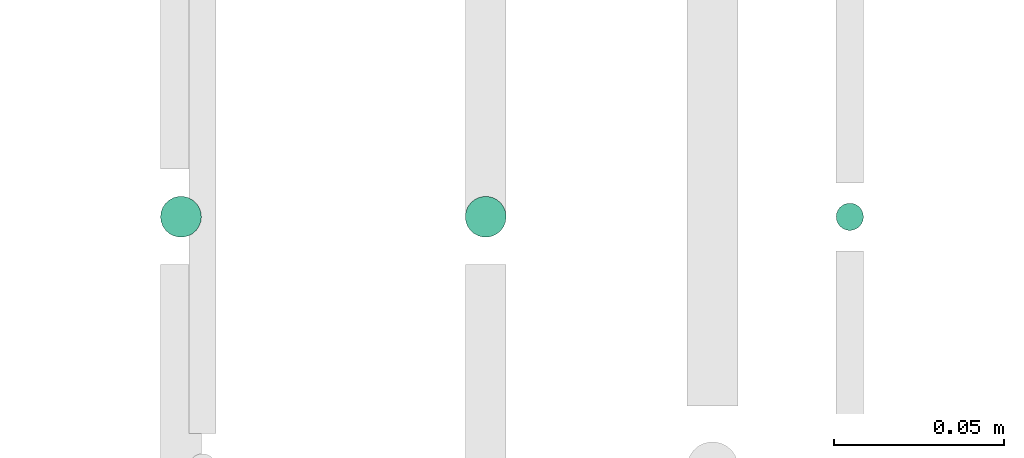
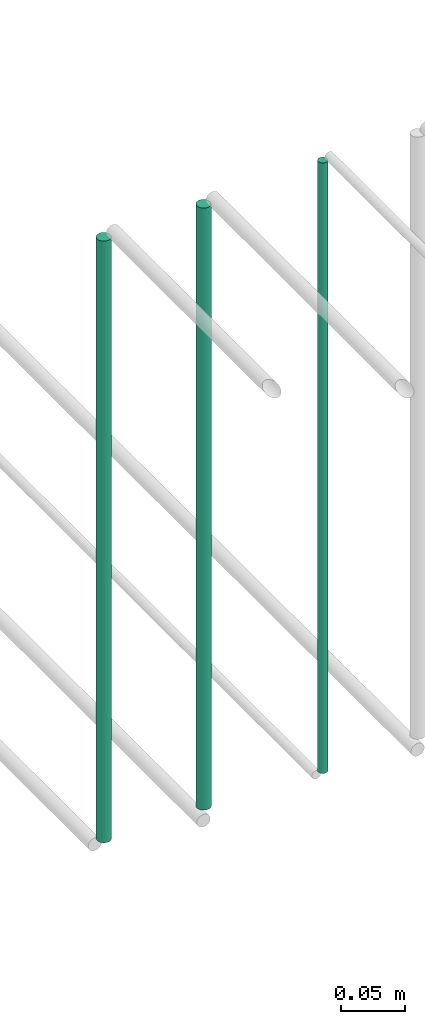
# One storey, part 214 of 331: 3 flow segments.
"""IFC2X3 building model written with IfcOpenShell, lengths in millimetres."""

from ifc_helpers import new_model, entity, si_unit, converted_unit, derived_unit, direction, frame, origin, origin_2d_with_axis, place, context, subcontext, project, spatial, circle, extrude, type_object, element, save


model = new_model("IFC2X3")

# Units and contexts
model_context = context("Model", 3, precision=0.01, world=origin(), true_north=direction((6.12303176911189e-17, 1.0)))
body_context = subcontext(model_context, "Body", "Model", "MODEL_VIEW")
ifc_project = project(units=[si_unit("LENGTHUNIT", "METRE", prefix="MILLI"), si_unit("AREAUNIT", "SQUARE_METRE"), si_unit("VOLUMEUNIT", "CUBIC_METRE"), converted_unit("PLANEANGLEUNIT", "DEGREE", entity("IfcRatioMeasure", 0.0174532925199433), si_unit("PLANEANGLEUNIT", "RADIAN"), dimensions=[0, 0, 0, 0, 0, 0, 0]), si_unit("MASSUNIT", "GRAM", prefix="KILO"), derived_unit("MASSDENSITYUNIT", [(si_unit("MASSUNIT", "GRAM", prefix="KILO"), 1), (si_unit("LENGTHUNIT", "METRE"), -3)]), derived_unit("MOMENTOFINERTIAUNIT", [(si_unit("LENGTHUNIT", "METRE"), 4)]), si_unit("TIMEUNIT", "SECOND"), si_unit("FREQUENCYUNIT", "HERTZ"), si_unit("THERMODYNAMICTEMPERATUREUNIT", "DEGREE_CELSIUS"), derived_unit("THERMALTRANSMITTANCEUNIT", [(si_unit("MASSUNIT", "GRAM", prefix="KILO"), 1), (si_unit("THERMODYNAMICTEMPERATUREUNIT", "KELVIN"), -1), (si_unit("TIMEUNIT", "SECOND"), -3)]), derived_unit("VOLUMETRICFLOWRATEUNIT", [(si_unit("LENGTHUNIT", "METRE"), 3), (si_unit("TIMEUNIT", "SECOND"), -1)]), derived_unit("MASSFLOWRATEUNIT", [(si_unit("MASSUNIT", "GRAM", prefix="KILO"), 1), (si_unit("TIMEUNIT", "SECOND"), -1)]), derived_unit("ROTATIONALFREQUENCYUNIT", [(si_unit("TIMEUNIT", "SECOND"), -1)]), si_unit("ELECTRICCURRENTUNIT", "AMPERE"), si_unit("ELECTRICVOLTAGEUNIT", "VOLT"), si_unit("POWERUNIT", "WATT"), si_unit("FORCEUNIT", "NEWTON", prefix="KILO"), si_unit("ILLUMINANCEUNIT", "LUX"), si_unit("LUMINOUSFLUXUNIT", "LUMEN"), si_unit("LUMINOUSINTENSITYUNIT", "CANDELA"), derived_unit("USERDEFINED", [(si_unit("MASSUNIT", "GRAM", prefix="KILO"), -1), (si_unit("LENGTHUNIT", "METRE"), -2), (si_unit("TIMEUNIT", "SECOND"), 3), (si_unit("LUMINOUSFLUXUNIT", "LUMEN"), 1)]), derived_unit("LINEARVELOCITYUNIT", [(si_unit("LENGTHUNIT", "METRE"), 1), (si_unit("TIMEUNIT", "SECOND"), -1)]), si_unit("PRESSUREUNIT", "PASCAL"), derived_unit("USERDEFINED", [(si_unit("LENGTHUNIT", "METRE"), -2), (si_unit("MASSUNIT", "GRAM", prefix="KILO"), 1), (si_unit("TIMEUNIT", "SECOND"), -2)]), derived_unit("LINEARFORCEUNIT", [(si_unit("MASSUNIT", "GRAM", prefix="KILO"), 1), (si_unit("LENGTHUNIT", "METRE"), 1), (si_unit("TIMEUNIT", "SECOND"), -2), (si_unit("LENGTHUNIT", "METRE"), -1)]), derived_unit("PLANARFORCEUNIT", [(si_unit("MASSUNIT", "GRAM", prefix="KILO"), 1), (si_unit("LENGTHUNIT", "METRE"), 1), (si_unit("TIMEUNIT", "SECOND"), -2), (si_unit("LENGTHUNIT", "METRE"), -2)])], contexts=[model_context])

# Site, building, storey
site_placement = place(None, frame((0.0, -0.00077364408347762, 0.0)))
site = spatial("IfcSite", under=ifc_project, at=site_placement, CompositionType="ELEMENT")
building_placement = place(site_placement, origin())
building = spatial("IfcBuilding", under=site, at=building_placement, CompositionType="ELEMENT")
storey_placement = place(building_placement, origin())
storey = spatial("IfcBuildingStorey", under=building, at=storey_placement, CompositionType="ELEMENT", Elevation=0.0)

# Flow segments
pipe_segment_type = type_object("IfcPipeSegmentType", PredefinedType="NOTDEFINED")
flow_segment_1_placement = place(storey_placement, frame((63262.1765027262, 5636.02529159143, 14564.3874126246)))
element("IfcFlowSegment", 1, at=flow_segment_1_placement, inside=storey, type_object=pipe_segment_type, context=body_context, shape_type="SweptSolid", body=[
    extrude(circle(Radius=6.0, at=origin_2d_with_axis()), frame((7.59527223591454, 7.59527223591562, 0.0), z_axis=(0.0, 0.0, 1.0), x_axis=(-1.0, 0.0, 0.0)), (0.0, 0.0, 1.0), 571.612587375415),
])
flow_segment_2_placement = place(storey_placement, frame((63351.7906839002, 5636.02529159143, 14564.0)))
element("IfcFlowSegment", 2, at=flow_segment_2_placement, inside=storey, type_object=pipe_segment_type, context=body_context, shape_type="SweptSolid", body=[
    extrude(circle(Radius=6.0, at=origin_2d_with_axis()), frame((7.59527223591454, 7.59527223591562, 0.0), z_axis=(0.0, 0.0, 1.0), x_axis=(-1.0, 0.0, 0.0)), (0.0, 0.0, 1.0), 572.000000000006),
])
flow_segment_3_placement = place(storey_placement, frame((63460.8735189448, 5638.02529159143, 14560.0)))
element("IfcFlowSegment", 3, at=flow_segment_3_placement, inside=storey, type_object=pipe_segment_type, context=body_context, shape_type="SweptSolid", body=[
    extrude(circle(Radius=4.0, at=origin_2d_with_axis()), frame((5.59527223591499, 5.59527223591607, 0.0), z_axis=(0.0, 0.0, 1.0), x_axis=(-1.0, 0.0, 0.0)), (0.0, 0.0, 1.0), 580.000000000022),
])

save(model, "model.ifc")
